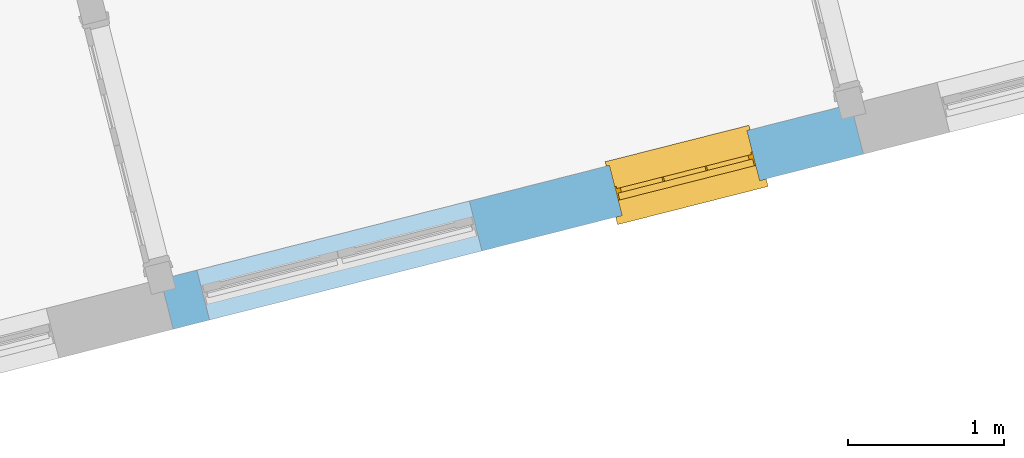
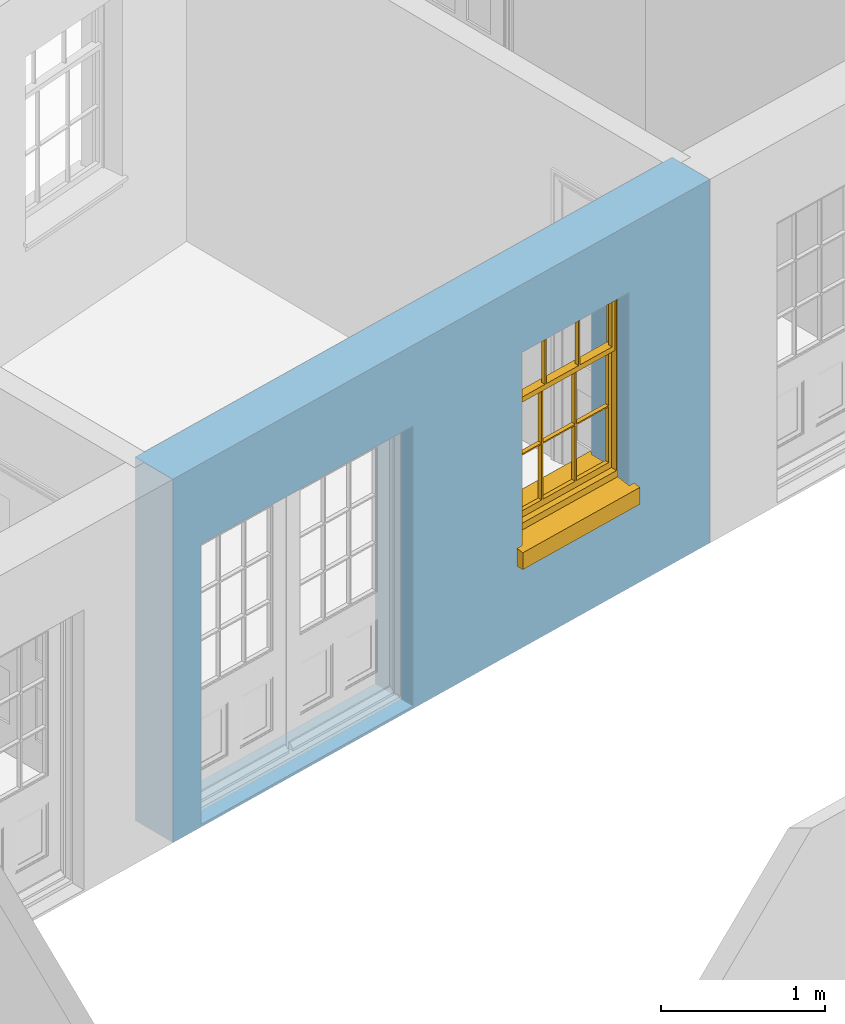
# One storey, part 4 of 15: 1 window, 2 openings, plus 1 element that does not belong to this part.
"""IFC2X3 building model written with IfcOpenShell, lengths in metres."""

from ifc_helpers import new_model, si_unit, frame, origin, place, context, subcontext, project, spatial, polyline, outline, extrude, faceted_brep, material, layer, layer_set, layer_usage, element, fill, save


model = new_model("IFC2X3")

# Units and contexts
model_context = context("Model", 3, world=origin())
body_context = subcontext(model_context, "Body", "Model", "MODEL_VIEW")
ifc_project = project(units=[si_unit("PLANEANGLEUNIT", "RADIAN"), si_unit("MASSUNIT", "GRAM", prefix="KILO"), si_unit("FORCEUNIT", "NEWTON", prefix="KILO"), si_unit("LENGTHUNIT", "METRE")], contexts=[model_context])

# Site, building, storey
site_placement = place(None, origin())
site = spatial("IfcSite", under=ifc_project, at=site_placement, CompositionType="ELEMENT")
building_placement = place(None, origin())
building = spatial("IfcBuilding", under=site, at=building_placement, Name="Building plot-13", CompositionType="ELEMENT")
storey_placement = place(None, frame((0.0, 0.0, 4.0)))
storey = spatial("IfcBuildingStorey", under=building, at=storey_placement, Name="Floor 0", CompositionType="ELEMENT", Elevation=4.0)

# Wall, openings, window
ifc_material = material(Name="Masonry")
ifc_layer = layer(ifc_material, 0.33, ventilated=False)
ifc_layer_set = layer_set([ifc_layer], Name="My Wall")
ifc_layer_usage = layer_usage(ifc_layer_set, "AXIS2", "NEGATIVE", 0.08)
wall_placement = place(storey_placement, origin())
wall = element("IfcWallStandardCase", 1, at=wall_placement, inside=storey, material=ifc_layer_usage, Name="exterior", context=body_context, shape_type="SweptSolid", body=[
    extrude(outline(polyline([(66.7491610907744, 43.8925759474061), (66.8302893451402, 43.5727037755256), (71.2509007169492, 44.6938906600119), (71.1697724625834, 45.0137628318924), (66.7491610907744, 43.8925759474061)])), origin(), (0.0, 0.0, 1.0), 2.7),
])
opening_1_placement = place(storey_placement, frame((0.0, 0.0, 0.0199999999999996)))
element("IfcOpeningElement", 2, at=opening_1_placement, cuts=wall, Name="Opening", ObjectType="Opening", context=body_context, shape_type="SweptSolid", body=[
    extrude(outline(polyline([(67.0630635375092, 43.631741621104), (68.8078208386756, 44.0742593721904), (68.7266925843098, 44.3941315440709), (66.9819352831434, 43.9516137929845), (67.0630635375092, 43.631741621104)])), origin(), (0.0, 0.0, 1.0), 2.08),
])
opening_2_placement = place(storey_placement, frame((0.0, 0.0, 0.75)))
opening_2 = element("IfcOpeningElement", 3, at=opening_2_placement, cuts=wall, Name="Opening", ObjectType="Opening", context=body_context, shape_type="SweptSolid", body=[
    extrude(outline(polyline([(69.7047120006465, 44.3017352851435), (70.5867837473473, 44.5254525926372), (70.5056554929815, 44.8453247645177), (69.6235837462807, 44.621607457024), (69.7047120006465, 44.3017352851435)])), origin(), (0.0, 0.0, 1.0), 1.445),
])
window_placement = place(storey_placement, frame((69.6432512018846, 44.5440626880833, 0.75), z_axis=(0.0, 0.0, 1.0), x_axis=(0.882071746700802, 0.223717307493636, 0.0)))
window = element("IfcWindow", 4, at=window_placement, inside=storey, Name="living outside window", OverallHeight=1.445, OverallWidth=0.91, context=body_context, shape_type="Brep", held_by="IfcProductRepresentation", body=[
    faceted_brep([(0.876875, -0.105, 0.999097), (0.876875, -0.105, 1.411875), (0.9, -0.105, 1.435), (0.033125, -0.105, 1.411875), (0.033125, -0.105, 0.999097), (0.01, -0.105, 1.435), (0.033125, -0.135, 1.411875), (0.01, -0.135, 1.435), (0.033125, -0.135, 0.999097), (0.876875, -0.135, 1.411875), (0.876875, -0.135, 0.999097), (0.9, -0.135, 1.435), (0.033125, -0.105, 0.960972), (0.01, -0.105, 0.960972), (0.033125, -0.105, 0.548195), (0.876875, -0.105, 0.960972), (0.876875, -0.105, 0.548195), (0.9, -0.105, 0.960972), (0.876875, -0.105, 0.538195), (0.876875, -0.105, 0.125417), (0.9, -0.105, 0.077167), (0.033125, -0.105, 0.125417), (0.033125, -0.105, 0.538195), (0.01, -0.105, 0.077167), (0.9, -0.135, 0.960972), (0.01, -0.135, 0.960972), (-0.0425, -0.25, 0.01), (-0.0425, -0.3, 0.001667), (0.0, -0.25, 0.01), (0.9525, -0.25, 0.01), (0.91, -0.25, 0.01), (0.9525, -0.3, 0.001667), (-0.02, 0.08, 0.077167), (0.0, 0.08, 0.077167), (-0.02, 0.11, 0.077167), (0.0, -0.06, 0.077167), (0.01, -0.06, 0.077167), (0.91, -0.06, 0.077167), (0.91, 0.08, 0.077167), (0.9, -0.06, 0.077167), (0.93, 0.08, 0.077167), (0.93, 0.11, 0.077167), (0.01, -0.105, 0.999097), (0.01, -0.075, 0.999097), (0.9, -0.105, 0.999097), (0.9, -0.075, 0.999097), (0.876875, -0.075, 0.125417), (0.876875, -0.075, 0.538195), (0.9, -0.075, 0.077167), (0.876875, -0.075, 0.548195), (0.876875, -0.075, 0.960972), (0.033125, -0.075, 0.125417), (0.01, -0.075, 0.077167), (0.033125, -0.075, 0.538195), (0.033125, -0.075, 0.960972), (0.033125, -0.075, 0.548195), (-0.02, 0.08, 0.052167), (-0.02, 0.11, 0.052167), (0.93, 0.11, 0.052167), (0.93, 0.08, 0.052167), (0.91, 0.08, 0.052167), (0.0, 0.08, 0.052167), (0.91, -0.15, 0.026667), (0.0, -0.15, 0.026667), (-0.0425, -0.3, -0.123333), (0.9525, -0.3, -0.123333), (-0.0425, -0.25, -0.123333), (0.9525, -0.25, -0.123333), (0.01, -0.06, 1.435), (0.9, -0.06, 1.435), (0.0, -0.06, 1.445), (0.91, -0.06, 1.445), (0.01, -0.15, 0.077167), (0.9, -0.15, 0.077167), (0.592292, -0.105, 0.125417), (0.592292, -0.075, 0.125417), (0.317708, -0.075, 0.125417), (0.317708, -0.105, 0.125417), (0.592292, -0.105, 0.548195), (0.317708, -0.105, 0.548195), (0.317708, -0.105, 0.538195), (0.592292, -0.105, 0.538195), (0.592292, -0.075, 0.548195), (0.317708, -0.075, 0.548195), (0.602292, -0.075, 0.548195), (0.602292, -0.105, 0.548195), (0.317708, -0.075, 0.538195), (0.307708, -0.075, 0.125417), (0.307708, -0.075, 0.538195), (0.602292, -0.075, 0.538195), (0.602292, -0.075, 0.125417), (0.592292, -0.075, 0.538195), (0.307708, -0.075, 0.548195), (0.317708, -0.075, 0.960972), (0.307708, -0.075, 0.960972), (0.602292, -0.075, 0.960972), (0.592292, -0.075, 0.960972), (0.307708, -0.105, 0.538195), (0.307708, -0.105, 0.125417), (0.307708, -0.105, 0.548195), (0.307708, -0.105, 0.960972), (0.592292, -0.105, 0.960972), (0.317708, -0.105, 0.960972), (0.602292, -0.105, 0.960972), (0.602292, -0.105, 0.538195), (0.602292, -0.105, 0.125417), (0.317708, -0.135, 1.411875), (0.307708, -0.135, 1.411875), (0.307708, -0.135, 0.999097), (0.317708, -0.135, 0.999097), (0.602292, -0.135, 1.411875), (0.592292, -0.135, 1.411875), (0.592292, -0.135, 0.999097), (0.602292, -0.135, 0.999097), (0.317708, -0.105, 0.999097), (0.307708, -0.105, 0.999097), (0.307708, -0.105, 1.411875), (0.317708, -0.105, 1.411875), (0.602292, -0.105, 0.999097), (0.592292, -0.105, 0.999097), (0.592292, -0.105, 1.411875), (0.602292, -0.105, 1.411875), (0.91, -0.15, 1.445), (0.9, -0.15, 1.435), (0.01, -0.15, 1.435), (0.0, -0.15, 1.445), (0.91, -0.25, 0.0), (0.0, -0.25, 0.0), (0.91, 0.08, 0.0), (0.0, 0.08, 0.0)], [[[0, 1, 2]], [[3, 4, 5]], [[6, 7, 8]], [[9, 10, 11]], [[12, 13, 14]], [[15, 16, 17]], [[18, 19, 20]], [[21, 22, 23]], [[24, 15, 17]], [[13, 12, 25]], [[26, 27, 28]], [[29, 30, 31]], [[32, 33, 34]], [[35, 36, 33]], [[37, 38, 39]], [[40, 41, 38]], [[42, 4, 43]], [[44, 45, 0]], [[46, 47, 48]], [[49, 50, 45]], [[51, 52, 53]], [[54, 55, 43]], [[38, 33, 36, 39]], [[41, 34, 33, 38]], [[56, 32, 34, 57]], [[57, 34, 41, 58]], [[58, 41, 40, 59]], [[57, 58, 60, 61]], [[52, 48, 39, 36]], [[62, 63, 28, 30]], [[27, 31, 30, 28]], [[27, 64, 65, 31]], [[66, 67, 65, 64]], [[2, 5, 68, 69]], [[68, 70, 71, 69]], [[20, 23, 72, 73]], [[73, 72, 63, 62]], [[74, 75, 76, 77]], [[78, 79, 80, 81]], [[78, 82, 83, 79]], [[16, 49, 84, 85]], [[86, 76, 87, 88]], [[89, 90, 75, 91]], [[92, 88, 53, 55]], [[82, 91, 86, 83]], [[93, 83, 92, 94]], [[95, 84, 82, 96]], [[89, 84, 49, 47]], [[97, 88, 87, 98]], [[22, 53, 88, 97]], [[81, 91, 75, 74]], [[80, 86, 91, 81]], [[77, 76, 86, 80]], [[99, 92, 55, 14]], [[100, 94, 92, 99]], [[101, 96, 82, 78]], [[79, 83, 93, 102]], [[85, 84, 95, 103]], [[104, 89, 47, 18]], [[105, 90, 89, 104]], [[104, 18, 16, 85]], [[80, 97, 98, 77]], [[104, 81, 74, 105]], [[103, 101, 78, 85]], [[99, 14, 22, 97]], [[102, 100, 99, 79]], [[106, 107, 108, 109]], [[110, 111, 112, 113]], [[114, 115, 116, 117]], [[118, 119, 120, 121]], [[107, 116, 115, 108]], [[111, 120, 119, 112]], [[109, 114, 117, 106]], [[113, 118, 121, 110]], [[85, 78, 81, 104]], [[84, 89, 91, 82]], [[83, 86, 88, 92]], [[79, 99, 97, 80]], [[109, 112, 119, 114]], [[102, 93, 96, 101]], [[106, 117, 120, 111]], [[98, 87, 51, 21]], [[6, 3, 116, 107]], [[110, 121, 1, 9]], [[19, 46, 90, 105]], [[26, 66, 64, 27]], [[29, 31, 65, 67]], [[25, 24, 112, 109]], [[11, 7, 106, 111]], [[75, 48, 52, 76]], [[43, 45, 96, 93]], [[45, 43, 114, 119]], [[5, 2, 120, 117]], [[24, 25, 102, 101]], [[42, 5, 4]], [[2, 44, 0]], [[49, 45, 48, 47]], [[52, 43, 55, 53]], [[14, 13, 23, 22]], [[20, 17, 16, 18]], [[24, 11, 10]], [[25, 8, 7]], [[8, 4, 3, 6]], [[9, 1, 0, 10]], [[15, 50, 49, 16]], [[18, 47, 46, 19]], [[21, 51, 53, 22]], [[14, 55, 54, 12]], [[44, 2, 69, 45]], [[68, 5, 42, 43]], [[36, 35, 70, 68]], [[39, 69, 71, 37]], [[62, 122, 123, 73]], [[63, 72, 124, 125]], [[8, 108, 115, 4]], [[113, 10, 0, 118]], [[94, 100, 12, 54]], [[17, 20, 73, 24]], [[72, 23, 13, 25]], [[52, 36, 68, 43]], [[69, 39, 48, 45]], [[11, 24, 73, 123]], [[7, 124, 72, 25]], [[23, 77, 98]], [[98, 21, 23]], [[105, 74, 20]], [[20, 19, 105]], [[20, 74, 77, 23]], [[113, 112, 24]], [[24, 10, 113]], [[25, 109, 108]], [[108, 8, 25]], [[110, 9, 11]], [[11, 111, 110]], [[7, 6, 107]], [[107, 106, 7]], [[5, 117, 116]], [[116, 3, 5]], [[121, 120, 2]], [[2, 1, 121]], [[11, 123, 124, 7]], [[122, 125, 124, 123]], [[43, 93, 94]], [[94, 54, 43]], [[96, 45, 95]], [[50, 95, 45]], [[15, 103, 95, 50]], [[48, 75, 90]], [[90, 46, 48]], [[87, 76, 52]], [[52, 51, 87]], [[103, 15, 24]], [[24, 101, 103]], [[100, 102, 25]], [[25, 12, 100]], [[115, 114, 43]], [[43, 4, 115]], [[118, 0, 45]], [[45, 119, 118]], [[71, 70, 125, 122]], [[70, 35, 63, 125]], [[122, 62, 37, 71]], [[126, 67, 66, 127]], [[60, 58, 59]], [[38, 60, 59, 40]], [[61, 56, 57]], [[32, 56, 61, 33]], [[61, 60, 128, 129]], [[62, 60, 38, 37]], [[126, 128, 60, 62]], [[33, 61, 63, 35]], [[61, 129, 127, 63]], [[128, 126, 127, 129]], [[28, 127, 66, 26]], [[63, 127, 28]], [[29, 67, 126, 30]], [[30, 126, 62]]]),
])
fill(opening_2, window)

save(model, "model.ifc")
